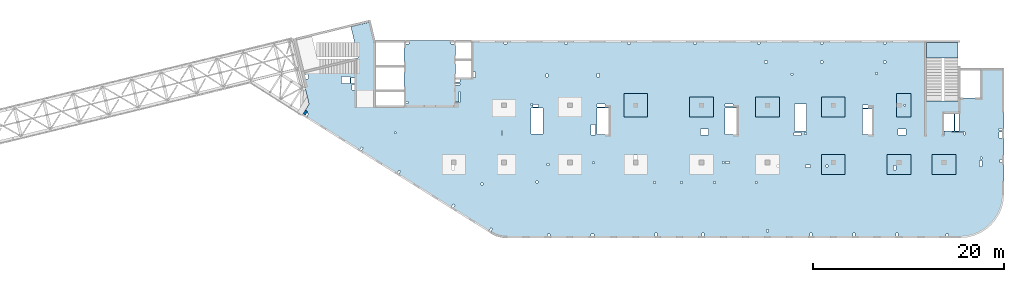
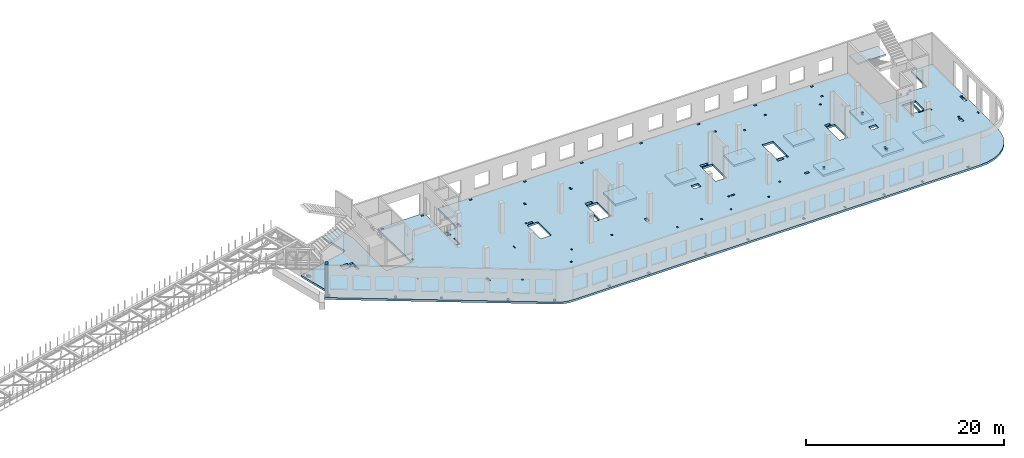
# One storey, part 14 of 66: 10 slabs, 1 wall.
"""IFC4 building model written with IfcOpenShell, lengths in millimetres."""

from ifc_helpers import new_model, entity, si_unit, converted_unit, derived_unit, direction, frame, origin, place, context, subcontext, project, spatial, indexed_curve, outline, extrude, material, type_object, element, save


model = new_model("IFC4")

# Units and contexts
model_context = context("Model", 3, precision=0.01, world=origin(), true_north=direction((6.12303176911189e-17, 1.0)))
plan_context = context("Plan", 3, precision=0.01, world=origin(), true_north=direction((6.12303176911189e-17, 1.0)))
body_context = subcontext(model_context, "Body", "Model", "MODEL_VIEW")
ifc_project = project(units=[si_unit("LENGTHUNIT", "METRE", prefix="MILLI"), si_unit("AREAUNIT", "SQUARE_METRE"), si_unit("VOLUMEUNIT", "CUBIC_METRE"), converted_unit("PLANEANGLEUNIT", "DEGREE", entity("IfcRatioMeasure", 0.0174532925199433), si_unit("PLANEANGLEUNIT", "RADIAN"), dimensions=[0, 0, 0, 0, 0, 0, 0]), si_unit("MASSUNIT", "GRAM", prefix="KILO"), derived_unit("MASSDENSITYUNIT", [(si_unit("MASSUNIT", "GRAM", prefix="KILO"), 1), (si_unit("LENGTHUNIT", "METRE"), -3)]), derived_unit("MOMENTOFINERTIAUNIT", [(si_unit("LENGTHUNIT", "METRE"), 4)]), si_unit("TIMEUNIT", "SECOND"), si_unit("FREQUENCYUNIT", "HERTZ"), si_unit("THERMODYNAMICTEMPERATUREUNIT", "DEGREE_CELSIUS"), derived_unit("THERMALTRANSMITTANCEUNIT", [(si_unit("MASSUNIT", "GRAM", prefix="KILO"), 1), (si_unit("THERMODYNAMICTEMPERATUREUNIT", "KELVIN"), -1), (si_unit("TIMEUNIT", "SECOND"), -3)]), derived_unit("VOLUMETRICFLOWRATEUNIT", [(si_unit("LENGTHUNIT", "METRE"), 3), (si_unit("TIMEUNIT", "SECOND"), -1)]), derived_unit("MASSFLOWRATEUNIT", [(si_unit("MASSUNIT", "GRAM", prefix="KILO"), 1), (si_unit("TIMEUNIT", "SECOND"), -1)]), derived_unit("ROTATIONALFREQUENCYUNIT", [(si_unit("TIMEUNIT", "SECOND"), -1)]), si_unit("ELECTRICCURRENTUNIT", "AMPERE"), si_unit("ELECTRICVOLTAGEUNIT", "VOLT"), si_unit("POWERUNIT", "WATT"), si_unit("FORCEUNIT", "NEWTON", prefix="KILO"), si_unit("ILLUMINANCEUNIT", "LUX"), si_unit("LUMINOUSFLUXUNIT", "LUMEN"), si_unit("LUMINOUSINTENSITYUNIT", "CANDELA"), derived_unit("USERDEFINED", [(si_unit("MASSUNIT", "GRAM", prefix="KILO"), -1), (si_unit("LENGTHUNIT", "METRE"), -2), (si_unit("TIMEUNIT", "SECOND"), 3), (si_unit("LUMINOUSFLUXUNIT", "LUMEN"), 1)]), derived_unit("LINEARVELOCITYUNIT", [(si_unit("LENGTHUNIT", "METRE"), 1), (si_unit("TIMEUNIT", "SECOND"), -1)]), si_unit("PRESSUREUNIT", "PASCAL"), derived_unit("USERDEFINED", [(si_unit("LENGTHUNIT", "METRE"), -2), (si_unit("MASSUNIT", "GRAM", prefix="KILO"), 1), (si_unit("TIMEUNIT", "SECOND"), -2)]), derived_unit("LINEARFORCEUNIT", [(si_unit("MASSUNIT", "GRAM", prefix="KILO"), 1), (si_unit("LENGTHUNIT", "METRE"), 1), (si_unit("TIMEUNIT", "SECOND"), -2), (si_unit("LENGTHUNIT", "METRE"), -1)]), derived_unit("PLANARFORCEUNIT", [(si_unit("MASSUNIT", "GRAM", prefix="KILO"), 1), (si_unit("LENGTHUNIT", "METRE"), 1), (si_unit("TIMEUNIT", "SECOND"), -2), (si_unit("LENGTHUNIT", "METRE"), -2)])], contexts=[model_context, plan_context])

# Site, building, storey
site_placement = place(None, origin())
site = spatial("IfcSite", under=ifc_project, at=site_placement, CompositionType="ELEMENT")
building_placement = place(site_placement, origin())
building = spatial("IfcBuilding", under=site, at=building_placement, CompositionType="ELEMENT")
storey_placement = place(building_placement, frame((0.0, 0.0, 19800.0)))
storey = spatial("IfcBuildingStorey", under=building, at=storey_placement, Name="06", CompositionType="ELEMENT", Elevation=19800.0)

# Slabs
ifc_material = material()
slab_type_1 = type_object("IfcSlabType", Name=":ADSK_ 25_250", PredefinedType="FLOOR", material=ifc_material)
placement = place(storey_placement, origin())
element("IfcSlab", 1, at=placement, inside=storey, type_object=slab_type_1, material=ifc_material, Name=":ADSK_ 25_250", ObjectType=":ADSK_ 25_250", PredefinedType="FLOOR", context=body_context, shape_type="SweptSolid", body=[
    extrude(outline(indexed_curve([(-25035.3578436615, -19149.6834192696), (-1723.7807546778, -19149.6834192696), (-1545.14847241192, -19144.6936708545), (-1367.07327148811, -19129.7399866024), (-1190.11049593861, -19104.8690009648), (-1014.81202059395, -19070.1582764174), (-841.72453001009, -19025.7160615744), (-671.387813581896, -18971.6809536053), (-504.333082159904, -18908.2214660066), (-341.081311419952, -18835.5355030768), (-182.14161715224, -18753.8497427335), (-28.0096675365007, -18663.4189295977), (40258.2427502764, 6510.83324029911), (40838.4797487777, 6940.19687309205), (41344.4069782413, 7455.0433348891), (41763.5656731431, 8042.69563789314), (42085.6347553066, 8688.68383209804), (42302.6838150429, 9377.10154425057), (42409.3683841568, 10090.9976455501), (42403.0615344909, 10812.7936446974), (42283.9185616152, 11524.7165286898), (42054.8731609348, 12209.2363933869), (41721.5651903726, 12849.4980879286), (34742.4070907115, 24018.2161483196), (32622.301916857, 22693.3954199037), (34265.0803766703, 20064.4637935763), (32314.5829786219, 18845.6283246935), (32494.7586566307, 18557.2939267212), (29662.2972177258, 16787.3328545174), (26286.6526837235, 22189.3629466861), (-14169.2074788393, -3090.87446333766), (-12102.4862527243, -6398.23995847165), (-13480.5550665628, -7259.37371366059), (-15547.2762926778, -3952.0082185266), (-20126.7049663564, -6813.62192807755), (-16496.694769283, -12622.7123467952), (-19040.8218102156, -14212.4977409902), (-22670.832007289, -8403.40732227252), (-22712.6876077937, -8429.56223563854), (-24284.2776411098, -6895.90698258245), (-24423.9609210558, -7039.04531184302), (-24280.8225917953, -7178.7285917891), (-25628.7662432749, -8560.01346915358), (-23238.3778486726, -10892.7277685588), (-27547.6230145679, -15308.5133809195), (-25035.3846887576, -17760.1502337417), (-25035.3578436615, -19149.6834192696)], self_intersect=False), holes=[indexed_curve([(-22133.29936942, -13415.1223301469), (-22442.8348260668, -13608.5462197739), (-22760.7919049058, -13099.7208115874), (-22451.256448259, -12906.2969219603), (-22133.29936942, -13415.1223301469)], self_intersect=False), indexed_curve([(-21775.5976557261, -13987.5509143567), (-21987.6082424705, -14120.0330305396), (-22284.3681827202, -13645.1293162322), (-22072.3575959758, -13512.6472000493), (-21775.5976557261, -13987.5509143567)], self_intersect=False), indexed_curve([(-11722.1849951182, -9261.85584637686), (-12086.8432043185, -9489.72508621147), (-12129.2374814971, -9421.88169845327), (-11832.4226600549, -9236.40673579719), (-12415.3439712598, -8303.56015412191), (-12347.5005835016, -8261.16587694338), (-11722.1849951182, -9261.85584637686)], self_intersect=False), indexed_curve([(-13242.0872574336, -7640.99276980047), (-13374.5693736165, -7428.98218305609), (-13009.9111644161, -7201.11294322148), (-12877.4290482332, -7413.12352996586), (-13242.0872574336, -7640.99276980047)], self_intersect=False), indexed_curve([(-5628.70693935832, -1916.57657305384), (-5459.09846996282, -1810.5908801075), (-5289.52136124868, -2081.96443114031), (-5459.12983064419, -2187.95012408664), (-5628.70693935832, -1916.57657305384)], self_intersect=False), indexed_curve([(34805.8880217444, 16198.6065676781), (34986.0636997531, 15910.2721697058), (34918.2203119949, 15867.8778925273), (34780.4389111647, 16088.3689027414), (33677.9838600939, 15399.4618985902), (33635.5895829154, 15467.3052863485), (34805.8880217444, 16198.6065676781)], self_intersect=False), indexed_curve([(37927.9797280557, 14617.8898262316), (38251.236091542, 14100.5839945753), (37988.3429639789, 13936.3061705085), (37665.0866004926, 14453.6120021647), (37927.9797280557, 14617.8898262316)], self_intersect=False), indexed_curve([(-1135.1376532047, 950.344261314779), (-940.08791339986, 1072.22780820307), (-749.313666096461, 766.932563291155), (-944.363405901299, 645.04901640287), (-1135.1376532047, 950.344261314779)], self_intersect=False), indexed_curve([(16089.6652817492, 11749.2314200073), (16259.2737511447, 11855.2171129536), (16365.259444091, 11685.6086435581), (16195.6509746955, 11579.6229506118), (16089.6652817492, 11749.2314200073)], self_intersect=False), indexed_curve([(23569.4069610802, 16517.5397477249), (23739.0154304757, 16623.5254406713), (23845.001123422, 16453.9169712758), (23675.3926540265, 16347.9312783294), (23569.4069610802, 16517.5397477249)], self_intersect=False), indexed_curve([(-4628.33119641944, -5064.85428712623), (-4495.84908023653, -5276.86487387061), (-4970.75279454395, -5573.62481412034), (-5103.23491072686, -5361.61422737596), (-4628.33119641944, -5064.85428712623)], self_intersect=False), indexed_curve([(-4030.49662256684, -5115.78386896694), (-2594.39048314403, -7413.97862927603), (-3662.92384033572, -8081.68849483792), (-5099.02997975852, -5783.49373452883), (-4030.49662256684, -5115.78386896694)], self_intersect=False), indexed_curve([(1253.91022629488, -1306.59011826816), (1423.48733500901, -1577.96366930096), (728.092610487371, -2012.50501038096), (558.515501773239, -1741.13145934816), (1253.91022629488, -1306.59011826816)], self_intersect=False), indexed_curve([(1843.25645725139, -1457.15866891798), (3313.80794688175, -3810.4761817806), (2245.27458969007, -4478.18604734249), (774.723100059713, -2124.86853447986), (1843.25645725139, -1457.15866891798)], self_intersect=False), indexed_curve([(1740.68547315327, -4840.66338935521), (1163.06344659577, -3916.29723114972), (1553.16292620543, -3672.53013737315), (2130.78495276294, -4596.89629557865), (1740.68547315327, -4840.66338935521)], self_intersect=False), indexed_curve([(11463.4910605066, 1234.9663319602), (11145.5339816676, 1743.79174014671), (11849.4091296589, 2183.63236587399), (12167.3662084979, 1674.80695768748), (11463.4910605066, 1234.9663319602)], self_intersect=False), indexed_curve([(14896.1975903923, 72.3933752474018), (15065.8060597878, 178.379068193729), (15171.7917527341, 8.77059879822273), (15002.1832833386, -97.2150941481066), (14896.1975903923, 72.3933752474018)], self_intersect=False), indexed_curve([(12634.6385227333, 5805.04987843064), (12788.3177775055, 5559.11759780716), (12059.0013591048, 5103.37911813794), (11905.3221043326, 5349.31139876142), (12634.6385227333, 5805.04987843064)], self_intersect=False), indexed_curve([(13207.0239067502, 5643.88275848624), (14677.5753963806, 3290.56524562361), (13609.0420391889, 2622.85538006173), (12138.4905495585, 4976.17289292435), (13207.0239067502, 5643.88275848624)], self_intersect=False), indexed_curve([(19150.2533898443, 9870.66027583487), (20665.8487989769, 7445.25916347915), (19597.3154417852, 6777.54929791726), (18081.7200326527, 9202.95041027297), (19150.2533898443, 9870.66027583487)], self_intersect=False), indexed_curve([(20240.2252958214, 7031.8953605626), (20399.2038352409, 6777.48265646934), (19780.1329219473, 6390.63487721523), (19621.1543825278, 6645.04758130849), (20240.2252958214, 7031.8953605626)], self_intersect=False), indexed_curve([(25270.9461080048, 13058.6252458208), (26685.8551088383, 10794.3521793908), (25837.8127618608, 10264.4237146591), (24422.9037610273, 12528.6967810891), (25270.9461080048, 13058.6252458208)], self_intersect=False), indexed_curve([(28111.3878345621, 15193.224926799), (27941.7793651666, 15087.2392338527), (27835.7936722203, 15256.8477032482), (28005.4021416158, 15362.8333961945), (28111.3878345621, 15193.224926799)], self_intersect=False), indexed_curve([(29412.3642136373, 13158.4498458438), (29730.3212924763, 12649.6244376573), (29115.4924335878, 12265.4274521827), (29017.9675636854, 12204.4856787385), (28700.0104848464, 12713.3110869251), (28797.5335120786, 12774.2517089133), (29412.3642136373, 13158.4498458438)], self_intersect=False), indexed_curve([(23022.5065390695, 4466.46925882629), (22598.4853655807, 4201.50502646046), (22466.0032493978, 4413.51561320483), (22890.0244228865, 4678.47984557067), (23022.5065390695, 4466.46925882629)], self_intersect=False), indexed_curve([(-10781.317628673, -1445.50910142009), (-11035.7303327662, -1604.48764083959), (-11141.7160257126, -1434.87917144409), (-10887.3033216193, -1275.90063202459), (-10781.317628673, -1445.50910142009)], self_intersect=False), indexed_curve([(-5396.2487253657, 1919.53664962593), (-5650.66142945896, 1760.55811020644), (-5756.64712240529, 1930.16657960194), (-5502.23441831203, 2089.14511902144), (-5396.2487253657, 1919.53664962593)], self_intersect=False), indexed_curve([(-19490.7125321322, -6887.87443421422), (-19745.1252362254, -7046.85297363371), (-19851.1109291718, -6877.24450423821), (-19596.6982250785, -6718.26596481871), (-19490.7125321322, -6887.87443421422)], self_intersect=False), indexed_curve([(200.830764685962, 5417.06451685487), (-53.5819394072999, 5258.08597743537), (-159.567632353634, 5427.69444683087), (94.8450717396271, 5586.67298625037), (200.830764685962, 5417.06451685487)], self_intersect=False), indexed_curve([(6052.32295883088, 9073.57092350331), (5797.91025473762, 8914.59238408381), (5691.92456179129, 9084.20085347932), (5946.33726588455, 9243.17939289881), (6052.32295883088, 9073.57092350331)], self_intersect=False), indexed_curve([(11734.2066835803, 12624.0916372054), (11479.793979487, 12465.1130977859), (11373.8082865407, 12634.7215671814), (11628.220990634, 12793.7001066009), (11734.2066835803, 12624.0916372054)], self_intersect=False), indexed_curve([(17331.286173632, 16121.6195044343), (17076.8734695387, 15962.6409650148), (16970.8877765924, 16132.2494344104), (17225.3004806856, 16291.2279738298), (17331.286173632, 16121.6195044343)], self_intersect=False), indexed_curve([(22928.3656636836, 19619.1473716633), (22673.9529595903, 19460.1688322438), (22567.967266644, 19629.7773016393), (22822.3799707373, 19788.7558410588), (22928.3656636836, 19619.1473716633)], self_intersect=False), indexed_curve([(23977.6240238523, 17940.0235246478), (23723.211319759, 17781.0449852283), (23617.2256268127, 17950.6534546238), (23871.6383309059, 18109.6319940433), (23977.6240238523, 17940.0235246478)], self_intersect=False), indexed_curve([(18380.5445338006, 14442.4956574189), (18126.1318297074, 14283.5171179994), (18020.1461367611, 14453.1255873949), (18274.5588408543, 14612.1041268144), (18380.5445338006, 14442.4956574189)], self_intersect=False), indexed_curve([(13419.4968039821, 11342.4141387387), (13165.0840998889, 11183.4355993192), (13059.0984069425, 11353.0440687147), (13313.5111110358, 11512.0226081342), (13419.4968039821, 11342.4141387387)], self_intersect=False), indexed_curve([(-22943.636825664, -13042.9957293671), (-22551.4897617626, -13670.5470661305), (-23314.7278740424, -14147.482684389), (-23706.8749379438, -13519.9313476256), (-22943.636825664, -13042.9957293671)], self_intersect=False), indexed_curve([(-26693.9639157555, -15722.3725280137), (-27051.8095806284, -15373.1644826066), (-26842.2848799564, -15158.457213386), (-26484.4419576682, -15507.6680692153), (-26693.9639157555, -15722.3725280137)], self_intersect=False), indexed_curve([(-24735.3672304539, -18649.9890495262), (-24535.3672304924, -18649.9851256142), (-24535.3613446244, -18949.9851255565), (-24735.3613445859, -18949.9890494685), (-24735.3672304539, -18649.9890495262)], self_intersect=False), indexed_curve([(-17995.3672317511, -18649.8568136923), (-17795.3672317896, -18649.8528897804), (-17795.3613459216, -18949.8528897226), (-17995.3613458831, -18949.8568136346), (-17995.3672317511, -18649.8568136923)], self_intersect=False), indexed_curve([(-13365.3672326422, -18649.7659751299), (-13165.3672326807, -18649.7620512179), (-13165.3613468127, -18949.7620511602), (-13365.3613467742, -18949.7659750722), (-13365.3672326422, -18649.7659751299)], self_intersect=False), indexed_curve([(-6665.36723393173, -18649.6345240786), (-6465.36723397022, -18649.6306001666), (-6465.36134810225, -18949.6306001088), (-6665.36134806376, -18949.6345240208), (-6665.36723393173, -18649.6345240786)], self_intersect=False), indexed_curve([(-1995.36723483054, -18649.5429007335), (-1795.36723486903, -18649.5389768216), (-1795.36134900105, -18949.5389767638), (-1995.36134896257, -18949.5429006758), (-1995.36723483054, -18649.5429007335)], self_intersect=False), indexed_curve([(-15760.2274862019, -15405.2679960053), (-15680.7382164921, -15532.4743480519), (-15807.9445685388, -15611.9636177617), (-15887.4338382485, -15484.7572657151), (-15760.2274862019, -15405.2679960053)], self_intersect=False), indexed_curve([(-16289.959946675, -12198.7303741582), (-16459.5684160705, -12304.7160671045), (-16565.5541090168, -12135.107597709), (-16395.9456396213, -12029.1219047627), (-16289.959946675, -12198.7303741582)], self_intersect=False), indexed_curve([(-5197.32627309738, -15136.9063702166), (-5091.34058015106, -15306.5148396121), (-5260.94904954656, -15412.5005325584), (-5366.93474249289, -15242.8920631629), (-5197.32627309738, -15136.9063702166)], self_intersect=False), indexed_curve([(-6114.83658600321, -9743.560306838), (-6199.64082070096, -9796.55315331116), (-6411.61220659362, -9457.33621452015), (-6326.80797189587, -9404.34336804699), (-6114.83658600321, -9743.560306838)], self_intersect=False), indexed_curve([(3605.89099011392, -15920.9764032486), (3711.87668306025, -16090.5848726441), (3457.463978967, -16249.5634120636), (3351.47828602067, -16079.9549426681), (3605.89099011392, -15920.9764032486)], self_intersect=False), indexed_curve([(7489.92493927099, -13493.9040347776), (7595.91063221732, -13663.5125041731), (7341.49792812406, -13822.4910435926), (7235.51223517773, -13652.8825741971), (7489.92493927099, -13493.9040347776)], self_intersect=False), indexed_curve([(-394.20584995626, -11887.8820242313), (-288.220157009933, -12057.4904936268), (-457.828626405432, -12163.4761865732), (-563.814319351763, -11993.8677171777), (-394.20584995626, -11887.8820242313)], self_intersect=False), indexed_curve([(-431.124438654749, -9705.87331256026), (-325.138745708416, -9875.48178195576), (-494.747215103917, -9981.4674749021), (-600.73290805025, -9811.85900550659), (-431.124438654749, -9705.87331256026)], self_intersect=False), indexed_curve([(-5353.39564282971, -5376.43340797962), (-5200.74802037376, -5281.04628432792), (-5094.76232742743, -5450.65475372343), (-5247.40994988338, -5546.04187737513), (-5353.39564282971, -5376.43340797962)], self_intersect=False), indexed_curve([(3535.0797832171, -7032.88826389166), (3641.06547616344, -7202.49673328717), (3471.45700676793, -7308.4824262335), (3365.4713138216, -7138.873956838), (3535.0797832171, -7032.88826389166)], self_intersect=False), indexed_curve([(-13069.8605063958, -7916.60653256817), (-13149.3497761055, -7789.40018052154), (-12784.6915669052, -7561.53094068692), (-12705.2022971954, -7688.73729273355), (-13069.8605063958, -7916.60653256817)], self_intersect=False), indexed_curve([(12872.8835369238, -10012.2583411499), (13042.4920063193, -9906.27264820362), (13201.4705457388, -10160.6853522969), (13031.8620763433, -10266.6710452432), (12872.8835369238, -10012.2583411499)], self_intersect=False), indexed_curve([(17070.6931544625, -7389.11244072825), (17240.301623858, -7283.12674778192), (17399.2801632775, -7537.53945187517), (17229.671693882, -7643.5251448215), (17070.6931544625, -7389.11244072825)], self_intersect=False), indexed_curve([(10078.5817186322, -5408.45531014478), (10184.5674115785, -5578.06377954029), (10014.958942183, -5684.04947248662), (9908.97324923671, -5514.44100309111), (10078.5817186322, -5408.45531014478)], self_intersect=False), indexed_curve([(12461.5807136391, -3919.35632424882), (12567.5664065854, -4088.96479364433), (12397.9579371899, -4194.95048659066), (12291.9722442436, -4025.34201719516), (12461.5807136391, -3919.35632424882)], self_intersect=False), indexed_curve([(15378.8463872417, -2096.40240557192), (15484.8320801881, -2266.01087496742), (15315.2236107926, -2371.99656791375), (15209.2379178463, -2202.38809851824), (15378.8463872417, -2096.40240557192)], self_intersect=False), indexed_curve([(19101.7522904731, 229.983554600057), (19207.7379834194, 60.3750852045558), (19038.1295140239, -45.6106077417833), (18932.1438210776, 123.99786165372), (19101.7522904731, 229.983554600057)], self_intersect=False), indexed_curve([(22566.0467637286, -3483.47693429318), (22735.6552331241, -3377.49124134686), (22894.6337725436, -3631.90394544011), (22725.0253031481, -3737.88963838644), (22566.0467637286, -3483.47693429318)], self_intersect=False), indexed_curve([(15193.0124118344, 257.868337903477), (15549.190197565, 480.43829309077), (15655.1758905113, 310.829823695274), (15298.9981047808, 88.2598685079719), (15193.0124118344, 257.868337903477)], self_intersect=False), indexed_curve([(20835.425907691, 7173.88561244634), (20665.8174382955, 7067.89991950001), (20559.8317453492, 7237.50838889551), (20729.4402147447, 7343.49408184184), (20835.425907691, 7173.88561244634)], self_intersect=False), indexed_curve([(26645.0912518388, -1406.22007390789), (26814.6997212343, -1300.23438096156), (26973.6782606538, -1554.64708505483), (26804.0697912583, -1660.63277800115), (26645.0912518388, -1406.22007390789)], self_intersect=False), indexed_curve([(30469.7622367074, 983.757302031897), (30639.3707061029, 1089.74299497822), (30798.3492455224, 835.330290884961), (30628.7407761269, 729.344597938634), (30469.7622367074, 983.757302031897)], self_intersect=False), indexed_curve([(34294.4332215761, 3373.73467797166), (34464.0416909716, 3479.72037091801), (34623.0202303911, 3225.30766682474), (34453.4117609956, 3119.3219738784), (34294.4332215761, 3373.73467797166)], self_intersect=False), indexed_curve([(24359.3123452595, 12630.4618627264), (24208.282732811, 12872.153931615), (24717.1081409975, 13190.111010454), (24868.137753446, 12948.4189415654), (24359.3123452595, 12630.4618627264)], self_intersect=False), indexed_curve([(38774.2071192719, 6055.15702917322), (39028.6198233651, 6214.13556859271), (39134.6055163114, 6044.52709919721), (38880.1928122182, 5885.54855977772), (38774.2071192719, 6055.15702917322)], self_intersect=False), indexed_curve([(37832.592604404, 14770.5374486875), (37662.9841350085, 14664.5517557412), (37556.9984420621, 14834.1602251367), (37726.6069114576, 14940.145918083), (37832.592604404, 14770.5374486875)], self_intersect=False), indexed_curve([(39633.5850115564, 15436.066880475), (39474.6064721369, 15690.4795845682), (39644.2142479431, 15796.4648441014), (39803.1927873626, 15542.0521400081), (39633.5850115564, 15436.066880475)], self_intersect=False), indexed_curve([(37667.5340334719, 18393.6239323588), (37921.9474311545, 18552.6029051915), (38027.9331241009, 18382.994435796), (37773.5197264183, 18224.0154629633), (37667.5340334719, 18393.6239323588)], self_intersect=False), indexed_curve([(37860.957923099, 18084.088475712), (38115.3713207816, 18243.0674485447), (38433.3283996206, 17734.2420403582), (38178.915001938, 17575.2630675255), (37860.957923099, 18084.088475712)], self_intersect=False), indexed_curve([(33008.038246152, 15075.158222447), (33188.2139241608, 14786.8238244747), (33120.3705364026, 14744.4295472962), (32940.1948583938, 15032.7639452685), (33008.038246152, 15075.158222447)], self_intersect=False), indexed_curve([(32802.046604642, 17216.3710665211), (33758.5674834826, 15685.6546302267), (32876.603442626, 15134.5290269058), (31920.0825637853, 16665.2454632002), (32802.046604642, 17216.3710665211)], self_intersect=False), indexed_curve([(33234.5482016005, 17486.6345835343), (34191.0690804411, 15955.9181472398), (33860.3325651199, 15749.2460459945), (32903.8116862793, 17279.9624822889), (33183.6656607819, 17454.8388756504), (33234.5482016005, 17486.6345835343)], self_intersect=False), indexed_curve([(-8724.99463551253, -15077.252738595), (-8428.2346952628, -15552.1564529024), (-8640.24528200717, -15684.6385690853), (-8937.0052222569, -15209.7348547779), (-8724.99463551253, -15077.252738595)], self_intersect=False), indexed_curve([(7203.41403081956, -4487.07820658831), (6923.56005631698, -4661.95459994976), (6642.6979700092, -4212.49215605167), (6922.55194451179, -4037.61576269022), (7203.41403081956, -4487.07820658831)], self_intersect=False), indexed_curve([(20197.470370807, 2760.1074425607), (20027.8619014115, 2654.12174961437), (19921.8762084652, 2823.73021900988), (20091.4846778607, 2929.7159119562), (20197.470370807, 2760.1074425607)], self_intersect=False), indexed_curve([(24577.608729869, 5497.18854393024), (24408.0002604735, 5391.20285098393), (24302.0145675272, 5560.81132037942), (24471.6230369227, 5666.79701332575), (24577.608729869, 5497.18854393024)], self_intersect=False), indexed_curve([(30785.2437920549, 8951.73517525887), (30573.2332053105, 8819.25305907597), (30308.2689729447, 9243.27423256473), (30520.2795596891, 9375.75634874763), (30785.2437920549, 8951.73517525887)], self_intersect=False), indexed_curve([(-15504.9135013378, -4397.21064997542), (-15759.326205431, -4556.18918939492), (-15865.3118983774, -4386.58071999942), (-15610.8991942841, -4227.60218057992), (-15504.9135013378, -4397.21064997542)], self_intersect=False), indexed_curve([(-12229.6379372401, -5817.35020929626), (-12017.6273504957, -5684.86809311334), (-11720.8674102459, -6159.77180742076), (-11932.8779969903, -6292.25392360367), (-12229.6379372401, -5817.35020929626)], self_intersect=False)]), frame((31379.03, 15612.53, -400.0), z_axis=(0.0, 0.0, 1.0), x_axis=(0.848042346977523, -0.52992846473166, 0.0)), (0.0, 0.0, 1.0), 249.999999999999),
])
slab_type_2 = type_object("IfcSlabType", Name=":ADSK_ 25_250", PredefinedType="FLOOR", material=ifc_material)
element("IfcSlab", 2, at=placement, inside=storey, type_object=slab_type_2, material=ifc_material, Name=":ADSK_ 25_250", ObjectType=":ADSK_ 25_250", PredefinedType="FLOOR", context=body_context, shape_type="SweptSolid", body=[
    extrude(outline(indexed_curve([(-1249.99990844727, -1049.99999999999), (1249.99990844727, -1049.99999999999), (1249.99990844727, 1049.99999999999), (-1249.99990844727, 1049.99999999999), (-1249.99990844727, -1049.99999999999)], self_intersect=False), holes=[indexed_curve([(534.999908447283, 49.999314856667), (534.999908447283, 249.999314856666), (734.999908447263, 249.999314856666), (734.999908447263, 49.999314856667), (534.999908447283, 49.999314856667)], self_intersect=False)]), frame((55670.0, 7500.0, -650.0), z_axis=(0.0, 0.0, 1.0), x_axis=(-1.0, 0.0, 0.0)), (0.0, 0.0, 1.0), 249.999999999999),
])
slab_type_3 = type_object("IfcSlabType", Name=":ADSK_ 25_250", PredefinedType="FLOOR", material=ifc_material)
element("IfcSlab", 3, at=placement, inside=storey, type_object=slab_type_3, material=ifc_material, Name=":ADSK_ 25_250", ObjectType=":ADSK_ 25_250", PredefinedType="FLOOR", context=body_context, shape_type="SweptSolid", body=[
    extrude(outline(indexed_curve([(-1249.99999999999, -1050.0), (1250.00000000001, -1050.0), (1250.00000000001, 1050.0), (-1249.99999999999, 1050.0), (-1249.99999999999, -1050.0)], self_intersect=False), holes=[indexed_curve([(340.000000000009, 110.000000000013), (340.000000000009, 610.000000000013), (590.000000000004, 610.000000000013), (590.000000000004, 110.000000000013), (340.000000000009, 110.000000000013)], self_intersect=False)]), frame((62570.0, 7500.0, -650.0), z_axis=(0.0, 0.0, 1.0), x_axis=(-1.0, 0.0, 0.0)), (0.0, 0.0, 1.0), 249.999999999999),
])
slab_type_4 = type_object("IfcSlabType", Name=":ADSK_ 25_250", PredefinedType="FLOOR", material=ifc_material)
element("IfcSlab", 4, at=placement, inside=storey, type_object=slab_type_4, material=ifc_material, Name=":ADSK_ 25_250", ObjectType=":ADSK_ 25_250", PredefinedType="FLOOR", context=body_context, shape_type="SweptSolid", body=[
    extrude(outline(indexed_curve([(-1050.0, -1249.99999999999), (1050.0, -1249.99999999999), (1050.0, 1250.00000000001), (-1050.0, 1250.00000000001), (-1050.0, -1249.99999999999)], self_intersect=False)), frame((67280.0, 7500.0, -400.0), z_axis=(0.0, 0.0, -1.0), x_axis=(0.0, 1.0, 0.0)), (0.0, 0.0, 1.0), 249.999999999999),
])
slab_type_5 = type_object("IfcSlabType", Name=":ADSK_ 25_250", PredefinedType="FLOOR", material=ifc_material)
element("IfcSlab", 5, at=placement, inside=storey, type_object=slab_type_5, material=ifc_material, Name=":ADSK_ 25_250", ObjectType=":ADSK_ 25_250", PredefinedType="FLOOR", context=body_context, shape_type="SweptSolid", body=[
    extrude(outline(indexed_curve([(-1250.0, -1250.0), (1250.0, -1250.0), (1250.0, 1250.0), (-1250.0, 1250.0), (-1250.0, -1250.0)], self_intersect=False)), frame((34970.0, 13700.0, -400.0), z_axis=(0.0, 0.0, -1.0), x_axis=(0.0, 1.0, 0.0)), (0.0, 0.0, 1.0), 249.999999999999),
])
slab_type_6 = type_object("IfcSlabType", Name=":ADSK_ 25_250", PredefinedType="FLOOR", material=ifc_material)
element("IfcSlab", 6, at=placement, inside=storey, type_object=slab_type_6, material=ifc_material, Name=":ADSK_ 25_250", ObjectType=":ADSK_ 25_250", PredefinedType="FLOOR", context=body_context, shape_type="SweptSolid", body=[
    extrude(outline(indexed_curve([(-1049.99999999999, -1250.0), (1049.99999999999, -1250.0), (1049.99999999999, 1249.99999999999), (-1049.99999999999, 1249.99999999999), (-1049.99999999999, -1250.0)], self_intersect=False)), frame((41870.0, 13500.0, -400.0), z_axis=(0.0, 0.0, -1.0), x_axis=(0.0, 1.0, 0.0)), (0.0, 0.0, 1.0), 249.999999999999),
])
slab_type_7 = type_object("IfcSlabType", Name=":ADSK_ 25_250", PredefinedType="FLOOR", material=ifc_material)
element("IfcSlab", 7, at=placement, inside=storey, type_object=slab_type_7, material=ifc_material, Name=":ADSK_ 25_250", ObjectType=":ADSK_ 25_250", PredefinedType="FLOOR", context=body_context, shape_type="SweptSolid", body=[
    extrude(outline(indexed_curve([(-1049.99999999999, -1249.99990844726), (1049.99999999999, -1249.99990844726), (1049.99999999999, 1249.99990844727), (-1049.99999999999, 1249.99990844727), (-1049.99999999999, -1249.99990844726)], self_intersect=False)), frame((55670.0, 13500.0, -400.0), z_axis=(0.0, 0.0, -1.0), x_axis=(0.0, 1.0, 0.0)), (0.0, 0.0, 1.0), 249.999999999999),
])
slab_type_8 = type_object("IfcSlabType", Name=":ADSK_ 25_250", PredefinedType="FLOOR", material=ifc_material)
element("IfcSlab", 8, at=placement, inside=storey, type_object=slab_type_8, material=ifc_material, Name=":ADSK_ 25_250", ObjectType=":ADSK_ 25_250", PredefinedType="FLOOR", context=body_context, shape_type="SweptSolid", body=[
    extrude(outline(indexed_curve([(-1000.00000000001, -1250.0), (500.000000000008, -1250.0), (500.000000000008, -250.00000000001), (500.000000000008, 249.999999999989), (500.000000000008, 1250.0), (-1000.00000000001, 1250.0), (-1000.00000000001, -1250.0)], self_intersect=False), holes=[indexed_curve([(-449.999999999993, -100.000000000005), (-449.999999999993, 99.9999999999946), (-250.000000000004, 99.9999999999946), (-250.000000000004, -100.000000000005), (-449.999999999993, -100.000000000005)], self_intersect=False)]), frame((62820.0, 13700.0, -650.0), z_axis=(0.0, 0.0, 1.0), x_axis=(-1.0, 0.0, 0.0)), (0.0, 0.0, 1.0), 249.999999999999),
])
slab_type_9 = type_object("IfcSlabType", Name=":ADSK_ 25_250", PredefinedType="FLOOR", material=ifc_material)
element("IfcSlab", 9, at=placement, inside=storey, type_object=slab_type_9, material=ifc_material, Name=":ADSK_ 25_250", ObjectType=":ADSK_ 25_250", PredefinedType="FLOOR", context=body_context, shape_type="SweptSolid", body=[
    extrude(outline(indexed_curve([(-1049.99999999999, -1249.99999999999), (1049.99999999999, -1249.99999999999), (1049.99999999999, 1250.0), (-1049.99999999999, 1250.0), (-1049.99999999999, -1249.99999999999)], self_intersect=False)), frame((48770.0, 13500.0, -400.0), z_axis=(0.0, 0.0, -1.0), x_axis=(0.0, 1.0, 0.0)), (0.0, 0.0, 1.0), 249.999999999999),
])
slab_type_10 = type_object("IfcSlabType", Name=":ADSK_ 25_200", PredefinedType="FLOOR", material=ifc_material)
element("IfcSlab", 10, at=placement, inside=storey, type_object=slab_type_10, material=ifc_material, Name=":ADSK_ 25_200", ObjectType=":ADSK_ 25_200", PredefinedType="FLOOR", context=body_context, shape_type="SweptSolid", body=[
    extrude(outline(indexed_curve([(-834.999999999999, -1670.00000000001), (835.000000000001, -1670.00000000001), (835.000000000001, 1670.00000000002), (-834.999999999999, 1670.00000000002), (-834.999999999999, -1670.00000000001)], self_intersect=False)), frame((67100.0, 19465.0, 2070.0), z_axis=(0.0, 0.0, -1.0), x_axis=(0.0, 1.0, 0.0)), (0.0, 0.0, 1.0), 199.999999999998),
])

# Wall
wall_type = type_object("IfcWallType", Name=":ADSK_ 25_300", PredefinedType="STANDARD")
wall_placement = place(storey_placement, frame((233.05, 12729.59, -150.0), z_axis=(0.0, 0.0, 1.0), x_axis=(0.529911826412026, 0.848052743777574, 0.0)))
element("IfcWall", 11, at=wall_placement, inside=storey, type_object=wall_type, material=ifc_material, Name=":ADSK_ 25_300", ObjectType=":ADSK_ 25_300", PredefinedType="NOTDEFINED", context=body_context, shape_type="SweptSolid", body=[
    extrude(outline(indexed_curve([(450.000000000002, 150.0), (-6.93711754706783e-13, 150.0), (6.85251855259139e-13, -150.0), (450.000000000004, -150.0), (450.000000000002, 150.0)], self_intersect=False)), origin(), (0.0, 0.0, 1.0), 3950.0),
])

save(model, "model.ifc")
